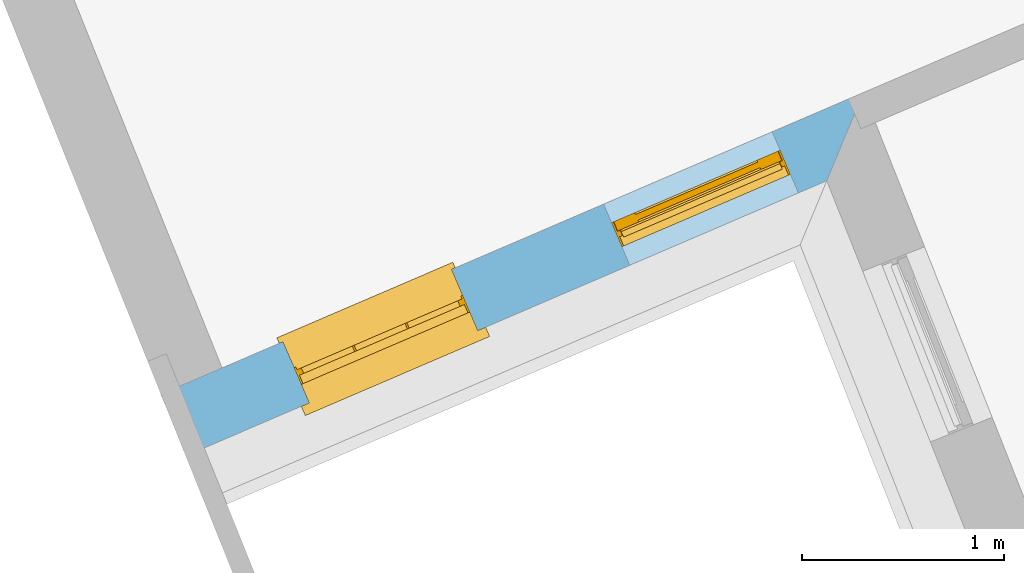
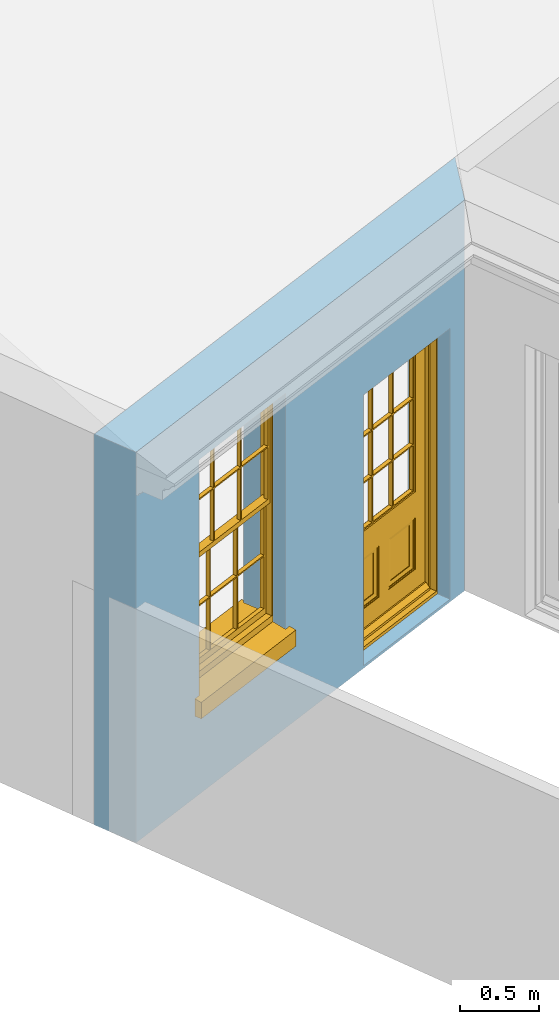
# One storey, part 10 of 19: 1 door, 1 window, 2 openings, plus 1 element that does not belong to this part.
"""IFC2X3 building model written with IfcOpenShell, lengths in metres."""

from ifc_helpers import new_model, si_unit, frame, origin, place, context, subcontext, project, spatial, polyline, outline, extrude, faceted_brep, material, layer, layer_set, layer_usage, element, fill, save


model = new_model("IFC2X3")

# Units and contexts
model_context = context("Model", 3, world=origin())
body_context = subcontext(model_context, "Body", "Model", "MODEL_VIEW")
ifc_project = project(units=[si_unit("PLANEANGLEUNIT", "RADIAN"), si_unit("MASSUNIT", "GRAM", prefix="KILO"), si_unit("FORCEUNIT", "NEWTON", prefix="KILO"), si_unit("LENGTHUNIT", "METRE")], contexts=[model_context])

# Site, building, storey
site_placement = place(None, origin())
site = spatial("IfcSite", under=ifc_project, at=site_placement, CompositionType="ELEMENT")
building_placement = place(None, origin())
building = spatial("IfcBuilding", under=site, at=building_placement, Name="Building plot-0", CompositionType="ELEMENT")
storey_placement = place(None, origin())
storey = spatial("IfcBuildingStorey", under=building, at=storey_placement, Name="Floor 0", CompositionType="ELEMENT", Elevation=0.0)

# Wall, openings, window, door
ifc_material = material(Name="Masonry")
ifc_layer = layer(ifc_material, 0.33, ventilated=False)
ifc_layer_set = layer_set([ifc_layer], Name="My Wall")
ifc_layer_usage = layer_usage(ifc_layer_set, "AXIS2", "NEGATIVE", 0.08)
wall_placement = place(storey_placement, origin())
wall = element("IfcWallStandardCase", 1, at=wall_placement, inside=storey, material=ifc_layer_usage, Name="exterior", context=body_context, shape_type="SweptSolid", body=[
    extrude(outline(polyline([(12.4783149609257, 29.6820741816785), (12.6084964326969, 29.3788370065046), (15.7818582558488, 30.741179576684), (15.9635555189143, 31.1783080951337), (12.4783149609257, 29.6820741816785)])), origin(), (0.0, 0.0, 1.0), 3.0),
])
opening_1_placement = place(storey_placement, frame((0.0, 0.0, 0.75)))
opening_1 = element("IfcOpeningElement", 2, at=opening_1_placement, cuts=wall, Name="Opening", ObjectType="Opening", context=body_context, shape_type="SweptSolid", body=[
    extrude(outline(polyline([(13.2150989386918, 29.6392549680068), (14.0512984217472, 29.9982402386486), (13.921116949976, 30.3014774138226), (13.0849174669206, 29.9424921431808), (13.2150989386918, 29.6392549680068)])), origin(), (0.0, 0.0, 1.0), 1.82),
])
opening_2_placement = place(storey_placement, frame((0.0, 0.0, 0.02)))
opening_2 = element("IfcOpeningElement", 3, at=opening_2_placement, cuts=wall, Name="Opening", ObjectType="Opening", context=body_context, shape_type="SweptSolid", body=[
    extrude(outline(polyline([(14.8050531683218, 30.3218315074543), (15.6412526513772, 30.6808167780961), (15.511071179606, 30.9840539532701), (14.6748716965506, 30.6250686826283), (14.8050531683218, 30.3218315074543)])), origin(), (0.0, 0.0, 1.0), 2.08),
])
window_placement = place(storey_placement, frame((13.1164766115924, 29.8689801007144, 0.75), z_axis=(0.0, 0.0, 1.0), x_axis=(0.836199483055472, 0.358985270641796, 0.0)))
window = element("IfcWindow", 4, at=window_placement, inside=storey, Name="bedroom outside window", OverallHeight=1.82, OverallWidth=0.91, context=body_context, shape_type="Brep", held_by="IfcProductRepresentation", body=[
    faceted_brep([(0.033125, -0.105, 0.975209), (0.01, -0.105, 0.975209), (0.033125, -0.105, 1.376042), (0.876875, -0.105, 0.975209), (0.876875, -0.105, 1.376042), (0.9, -0.105, 0.975209), (0.876875, -0.105, 1.386042), (0.876875, -0.105, 1.786875), (0.9, -0.105, 1.81), (0.033125, -0.105, 1.786875), (0.033125, -0.105, 1.386042), (0.01, -0.105, 1.81), (0.876875, -0.135, 1.376042), (0.876875, -0.135, 0.975209), (0.9, -0.135, 0.937083), (0.033125, -0.135, 1.786875), (0.01, -0.135, 1.81), (0.033125, -0.135, 1.386042), (0.01, -0.135, 0.937083), (0.033125, -0.135, 0.975209), (0.033125, -0.135, 1.376042), (0.876875, -0.135, 1.786875), (0.876875, -0.135, 1.386042), (0.9, -0.135, 1.81), (0.033125, -0.105, 0.937083), (0.01, -0.105, 0.937083), (0.033125, -0.105, 0.53625), (0.876875, -0.105, 0.937083), (0.876875, -0.105, 0.53625), (0.9, -0.105, 0.937083), (0.876875, -0.105, 0.52625), (0.876875, -0.105, 0.125417), (0.9, -0.105, 0.077167), (0.033125, -0.105, 0.125417), (0.033125, -0.105, 0.52625), (0.01, -0.105, 0.077167), (-0.0425, -0.25, 0.01), (-0.0425, -0.3, 0.001667), (0.0, -0.25, 0.01), (0.9525, -0.25, 0.01), (0.91, -0.25, 0.01), (0.9525, -0.3, 0.001667), (-0.02, 0.08, 0.077167), (0.0, 0.08, 0.077167), (-0.02, 0.11, 0.077167), (0.0, -0.06, 0.077167), (0.01, -0.06, 0.077167), (0.91, -0.06, 0.077167), (0.91, 0.08, 0.077167), (0.9, -0.06, 0.077167), (0.93, 0.08, 0.077167), (0.93, 0.11, 0.077167), (0.01, -0.075, 0.975209), (0.9, -0.075, 0.975209), (0.876875, -0.075, 0.125417), (0.876875, -0.075, 0.52625), (0.9, -0.075, 0.077167), (0.876875, -0.075, 0.53625), (0.876875, -0.075, 0.937083), (0.033125, -0.075, 0.125417), (0.01, -0.075, 0.077167), (0.033125, -0.075, 0.52625), (0.033125, -0.075, 0.937083), (0.033125, -0.075, 0.53625), (-0.02, 0.08, 0.052167), (-0.02, 0.11, 0.052167), (0.93, 0.11, 0.052167), (0.93, 0.08, 0.052167), (0.91, 0.08, 0.052167), (0.0, 0.08, 0.052167), (0.91, -0.15, 0.026667), (0.0, -0.15, 0.026667), (-0.0425, -0.3, -0.123333), (0.9525, -0.3, -0.123333), (-0.0425, -0.25, -0.123333), (0.9525, -0.25, -0.123333), (0.01, -0.06, 1.81), (0.9, -0.06, 1.81), (0.0, -0.06, 1.82), (0.91, -0.06, 1.82), (0.01, -0.15, 0.077167), (0.9, -0.15, 0.077167), (0.592292, -0.105, 0.125417), (0.592292, -0.075, 0.125417), (0.317708, -0.075, 0.125417), (0.317708, -0.105, 0.125417), (0.592292, -0.105, 0.53625), (0.317708, -0.105, 0.53625), (0.317708, -0.105, 0.52625), (0.592292, -0.105, 0.52625), (0.592292, -0.075, 0.53625), (0.317708, -0.075, 0.53625), (0.592292, -0.135, 1.386042), (0.592292, -0.105, 1.386042), (0.317708, -0.105, 1.386042), (0.317708, -0.135, 1.386042), (0.317708, -0.135, 1.376042), (0.592292, -0.135, 1.376042), (0.317708, -0.105, 1.376042), (0.592292, -0.105, 1.376042), (0.602292, -0.135, 1.376042), (0.592292, -0.135, 0.975209), (0.602292, -0.135, 0.975209), (0.602292, -0.105, 0.975209), (0.592292, -0.105, 0.975209), (0.602292, -0.105, 1.376042), (0.602292, -0.075, 0.53625), (0.602292, -0.105, 0.53625), (0.317708, -0.075, 0.52625), (0.307708, -0.075, 0.125417), (0.307708, -0.075, 0.52625), (0.602292, -0.075, 0.52625), (0.602292, -0.075, 0.125417), (0.592292, -0.075, 0.52625), (0.307708, -0.075, 0.53625), (0.317708, -0.075, 0.937083), (0.307708, -0.075, 0.937083), (0.602292, -0.075, 0.937083), (0.592292, -0.075, 0.937083), (0.307708, -0.105, 0.52625), (0.307708, -0.105, 0.125417), (0.307708, -0.105, 0.53625), (0.307708, -0.105, 0.937083), (0.592292, -0.105, 0.937083), (0.317708, -0.105, 0.937083), (0.602292, -0.105, 0.937083), (0.602292, -0.105, 0.52625), (0.602292, -0.105, 0.125417), (0.307708, -0.135, 1.386042), (0.307708, -0.135, 1.376042), (0.307708, -0.135, 0.975209), (0.317708, -0.135, 0.975209), (0.317708, -0.135, 1.786875), (0.307708, -0.135, 1.786875), (0.602292, -0.135, 1.786875), (0.592292, -0.135, 1.786875), (0.602292, -0.135, 1.386042), (0.602292, -0.105, 1.386042), (0.307708, -0.105, 1.386042), (0.307708, -0.105, 1.786875), (0.317708, -0.105, 1.786875), (0.592292, -0.105, 1.786875), (0.602292, -0.105, 1.786875), (0.307708, -0.105, 1.376042), (0.317708, -0.105, 0.975209), (0.307708, -0.105, 0.975209), (0.91, -0.15, 1.82), (0.9, -0.15, 1.81), (0.01, -0.15, 1.81), (0.0, -0.15, 1.82), (0.91, -0.25, 0.0), (0.0, -0.25, 0.0), (0.91, 0.08, 0.0), (0.0, 0.08, 0.0)], [[[0, 1, 2]], [[3, 4, 5]], [[6, 7, 8]], [[9, 10, 11]], [[12, 13, 14]], [[15, 16, 17]], [[18, 19, 20]], [[21, 22, 23]], [[24, 25, 26]], [[27, 28, 29]], [[30, 31, 32]], [[33, 34, 35]], [[14, 27, 29]], [[25, 24, 18]], [[36, 37, 38]], [[39, 40, 41]], [[42, 43, 44]], [[45, 46, 43]], [[47, 48, 49]], [[50, 51, 48]], [[1, 0, 52]], [[5, 53, 3]], [[54, 55, 56]], [[57, 58, 53]], [[59, 60, 61]], [[62, 63, 52]], [[48, 43, 46, 49]], [[51, 44, 43, 48]], [[64, 42, 44, 65]], [[65, 44, 51, 66]], [[66, 51, 50, 67]], [[65, 66, 68, 69]], [[60, 56, 49, 46]], [[70, 71, 38, 40]], [[37, 41, 40, 38]], [[37, 72, 73, 41]], [[74, 75, 73, 72]], [[8, 11, 76, 77]], [[76, 78, 79, 77]], [[32, 35, 80, 81]], [[81, 80, 71, 70]], [[82, 83, 84, 85]], [[86, 87, 88, 89]], [[86, 90, 91, 87]], [[92, 93, 94, 95]], [[92, 95, 96, 97]], [[96, 98, 99, 97]], [[100, 97, 101, 102]], [[103, 104, 99, 105]], [[97, 99, 104, 101]], [[102, 103, 105, 100]], [[28, 57, 106, 107]], [[108, 84, 109, 110]], [[111, 112, 83, 113]], [[114, 110, 61, 63]], [[90, 113, 108, 91]], [[115, 91, 114, 116]], [[117, 106, 90, 118]], [[111, 106, 57, 55]], [[119, 110, 109, 120]], [[34, 61, 110, 119]], [[89, 113, 83, 82]], [[88, 108, 113, 89]], [[85, 84, 108, 88]], [[121, 114, 63, 26]], [[122, 116, 114, 121]], [[123, 118, 90, 86]], [[87, 91, 115, 124]], [[107, 106, 117, 125]], [[126, 111, 55, 30]], [[127, 112, 111, 126]], [[126, 30, 28, 107]], [[88, 119, 120, 85]], [[126, 89, 82, 127]], [[125, 123, 86, 107]], [[121, 26, 34, 119]], [[124, 122, 121, 87]], [[128, 17, 20, 129]], [[96, 129, 130, 131]], [[132, 133, 128, 95]], [[134, 135, 92, 136]], [[100, 12, 22, 136]], [[137, 6, 4, 105]], [[94, 138, 139, 140]], [[137, 93, 141, 142]], [[99, 98, 94, 93]], [[143, 2, 10, 138]], [[144, 145, 143, 98]], [[129, 143, 145, 130]], [[20, 2, 143, 129]], [[131, 144, 98, 96]], [[128, 138, 10, 17]], [[133, 139, 138, 128]], [[135, 141, 93, 92]], [[95, 94, 140, 132]], [[22, 6, 137, 136]], [[136, 137, 142, 134]], [[100, 105, 4, 12]], [[107, 86, 89, 126]], [[106, 111, 113, 90]], [[91, 108, 110, 114]], [[87, 121, 119, 88]], [[97, 100, 136, 92]], [[129, 96, 95, 128]], [[98, 143, 138, 94]], [[105, 99, 93, 137]], [[131, 101, 104, 144]], [[124, 115, 118, 123]], [[132, 140, 141, 135]], [[120, 109, 59, 33]], [[15, 9, 139, 133]], [[134, 142, 7, 21]], [[31, 54, 112, 127]], [[36, 74, 72, 37]], [[39, 41, 73, 75]], [[18, 14, 101, 131]], [[23, 16, 132, 135]], [[83, 56, 60, 84]], [[52, 53, 118, 115]], [[53, 52, 144, 104]], [[11, 8, 141, 140]], [[14, 18, 124, 123]], [[2, 1, 11, 10]], [[8, 5, 4, 6]], [[57, 53, 56, 55]], [[60, 52, 63, 61]], [[26, 25, 35, 34]], [[32, 29, 28, 30]], [[14, 23, 22, 12]], [[18, 20, 17, 16]], [[19, 0, 2, 20]], [[17, 10, 9, 15]], [[12, 4, 3, 13]], [[21, 7, 6, 22]], [[27, 58, 57, 28]], [[30, 55, 54, 31]], [[33, 59, 61, 34]], [[26, 63, 62, 24]], [[5, 8, 77, 53]], [[76, 11, 1, 52]], [[46, 45, 78, 76]], [[49, 77, 79, 47]], [[70, 146, 147, 81]], [[71, 80, 148, 149]], [[19, 130, 145, 0]], [[102, 13, 3, 103]], [[116, 122, 24, 62]], [[29, 32, 81, 14]], [[80, 35, 25, 18]], [[60, 46, 76, 52]], [[77, 49, 56, 53]], [[23, 14, 81, 147]], [[16, 148, 80, 18]], [[35, 85, 120]], [[120, 33, 35]], [[127, 82, 32]], [[32, 31, 127]], [[32, 82, 85, 35]], [[102, 101, 14]], [[14, 13, 102]], [[18, 131, 130]], [[130, 19, 18]], [[134, 21, 23]], [[23, 135, 134]], [[16, 15, 133]], [[133, 132, 16]], [[11, 140, 139]], [[139, 9, 11]], [[142, 141, 8]], [[8, 7, 142]], [[23, 147, 148, 16]], [[146, 149, 148, 147]], [[52, 115, 116]], [[116, 62, 52]], [[118, 53, 117]], [[58, 117, 53]], [[27, 125, 117, 58]], [[56, 83, 112]], [[112, 54, 56]], [[109, 84, 60]], [[60, 59, 109]], [[125, 27, 14]], [[14, 123, 125]], [[122, 124, 18]], [[18, 24, 122]], [[145, 144, 52]], [[52, 0, 145]], [[103, 3, 53]], [[53, 104, 103]], [[79, 78, 149, 146]], [[78, 45, 71, 149]], [[146, 70, 47, 79]], [[150, 75, 74, 151]], [[68, 66, 67]], [[48, 68, 67, 50]], [[69, 64, 65]], [[42, 64, 69, 43]], [[69, 68, 152, 153]], [[70, 68, 48, 47]], [[150, 152, 68, 70]], [[43, 69, 71, 45]], [[69, 153, 151, 71]], [[152, 150, 151, 153]], [[38, 151, 74, 36]], [[71, 151, 38]], [[39, 75, 150, 40]], [[40, 150, 70]]]),
])
fill(opening_1, window)
door_placement = place(storey_placement, frame((14.7064308412224, 30.5515566401619, 0.02), z_axis=(0.0, 0.0, 1.0), x_axis=(0.836199483055472, 0.358985270641796, 0.0)))
door = element("IfcDoor", 5, at=door_placement, inside=storey, Name="bedroom outside door", OverallHeight=2.08, OverallWidth=0.91, context=body_context, shape_type="Brep", held_by="IfcProductRepresentation", body=[
    faceted_brep([(0.545, -0.055, 0.265), (0.745, -0.055, 0.265), (0.745, -0.05, 0.265), (0.545, -0.05, 0.265), (0.745, -0.05, 0.58), (0.545, -0.05, 0.58), (0.545, -0.055, 0.58), (0.515, -0.06, 0.235), (0.775, -0.06, 0.235), (0.745, -0.055, 0.58), (0.515, -0.06, 0.61), (0.515, -0.065, 0.235), (0.775, -0.065, 0.235), (0.775, -0.06, 0.61), (0.515, -0.065, 0.61), (0.785, -0.065, 0.225), (0.505, -0.065, 0.225), (0.775, -0.065, 0.61), (0.505, -0.065, 0.62), (0.785, -0.065, 0.62), (0.505, -0.07, 0.225), (0.785, -0.07, 0.225), (0.505, -0.07, 0.62), (0.785, -0.07, 0.62), (0.883, -0.07, 0.075), (0.898, -0.07, 0.075), (0.405, -0.07, 0.62), (0.405, -0.07, 0.225), (0.027, -0.07, 0.075), (0.785, -0.07, 0.82), (0.125, -0.07, 0.82), (0.405, -0.065, 0.62), (0.405, -0.065, 0.225), (0.898, -0.07, 2.068), (0.027, -0.08, 0.075), (0.883, -0.08, 0.075), (0.125, -0.07, 0.225), (0.012, -0.07, 0.075), (0.785, -0.06, 0.82), (0.125, -0.06, 0.82), (0.125, -0.07, 0.62), (0.125, -0.065, 0.62), (0.395, -0.065, 0.61), (0.395, -0.065, 0.235), (0.125, -0.065, 0.225), (0.785, -0.07, 1.895), (0.027, -0.11, 0.045), (0.883, -0.11, 0.045), (0.558333, -0.06, 0.83), (0.351667, -0.06, 0.83), (0.125, -0.07, 1.895), (0.125, -0.06, 1.895), (0.785, -0.06, 1.895), (0.012, -0.07, 2.068), (0.135, -0.065, 0.61), (0.395, -0.06, 0.61), (0.395, -0.06, 0.235), (0.135, -0.065, 0.235), (0.027, -0.11, 0.027), (0.883, -0.11, 0.027), (0.568333, -0.06, 0.83), (0.558333, -0.03, 0.83), (0.351667, -0.03, 0.83), (0.341667, -0.06, 0.83), (0.135, -0.06, 1.185), (0.135, -0.06, 1.53), (0.775, -0.06, 1.53), (0.775, -0.06, 1.185), (0.135, -0.06, 0.61), (0.365, -0.055, 0.58), (0.365, -0.055, 0.265), (0.135, -0.06, 0.235), (0.568333, -0.06, 1.175), (0.558333, -0.06, 1.175), (0.775, -0.06, 0.83), (0.558333, -0.03, 1.175), (0.785, -0.03, 0.82), (0.125, -0.03, 0.82), (0.351667, -0.03, 1.175), (0.351667, -0.06, 1.175), (0.341667, -0.06, 1.175), (0.135, -0.06, 0.83), (0.135, -0.06, 1.175), (0.135, -0.03, 1.185), (0.135, -0.03, 1.53), (0.135, -0.06, 1.54), (0.351667, -0.06, 1.885), (0.558333, -0.06, 1.885), (0.775, -0.03, 1.53), (0.775, -0.03, 1.185), (0.775, -0.06, 1.175), (0.775, -0.06, 1.54), (0.165, -0.055, 0.58), (0.365, -0.05, 0.58), (0.365, -0.05, 0.265), (0.165, -0.055, 0.265), (0.568333, -0.03, 0.83), (0.568333, -0.03, 1.175), (0.568333, -0.06, 1.185), (0.558333, -0.06, 1.185), (0.775, -0.03, 0.83), (0.785, -0.02, 0.82), (0.125, -0.02, 0.82), (0.341667, -0.03, 0.83), (0.341667, -0.03, 1.175), (0.351667, -0.06, 1.185), (0.341667, -0.06, 1.185), (0.135, -0.03, 0.83), (0.341667, -0.03, 1.185), (0.125, -0.03, 1.895), (0.341667, -0.03, 1.53), (0.341667, -0.06, 1.53), (0.135, -0.06, 1.885), (0.341667, -0.06, 1.54), (0.341667, -0.06, 1.885), (0.558333, -0.03, 1.885), (0.351667, -0.03, 1.885), (0.568333, -0.06, 1.885), (0.785, -0.03, 1.895), (0.568333, -0.03, 1.185), (0.568333, -0.06, 1.53), (0.568333, -0.03, 1.53), (0.568333, -0.06, 1.54), (0.775, -0.06, 1.885), (0.165, -0.05, 0.58), (0.165, -0.05, 0.265), (0.775, -0.03, 1.175), (0.558333, -0.06, 1.53), (0.351667, -0.03, 1.185), (0.558333, -0.03, 1.185), (0.505, -0.02, 0.62), (0.405, -0.02, 0.62), (0.125, -0.02, 1.895), (0.785, -0.02, 1.895), (0.351667, -0.06, 1.53), (0.135, -0.03, 1.175), (0.135, -0.03, 1.54), (0.341667, -0.03, 1.54), (0.135, -0.03, 1.885), (0.351667, -0.06, 1.54), (0.558333, -0.03, 1.54), (0.558333, -0.06, 1.54), (0.351667, -0.03, 1.54), (0.775, -0.03, 1.54), (0.568333, -0.03, 1.54), (0.775, -0.03, 1.885), (0.558333, -0.03, 1.53), (0.405, -0.02, 0.225), (0.505, -0.02, 0.225), (0.125, -0.02, 0.62), (0.785, -0.02, 0.62), (0.012, -0.02, 2.068), (0.898, -0.02, 2.068), (0.351667, -0.03, 1.53), (0.341667, -0.03, 1.885), (0.568333, -0.03, 1.885), (0.405, -0.025, 0.225), (0.405, -0.025, 0.62), (0.505, -0.025, 0.62), (0.505, -0.025, 0.225), (0.898, -0.02, 0.027), (0.012, -0.02, 0.027), (0.125, -0.025, 0.62), (0.785, -0.025, 0.62), (0.395, -0.025, 0.235), (0.395, -0.025, 0.61), (0.125, -0.02, 0.225), (0.125, -0.025, 0.225), (0.515, -0.025, 0.61), (0.515, -0.025, 0.235), (0.785, -0.02, 0.225), (0.785, -0.025, 0.225), (0.135, -0.025, 0.61), (0.775, -0.025, 0.61), (0.135, -0.025, 0.235), (0.395, -0.03, 0.235), (0.395, -0.03, 0.61), (0.515, -0.03, 0.61), (0.515, -0.03, 0.235), (0.775, -0.025, 0.235), (0.135, -0.03, 0.61), (0.775, -0.03, 0.61), (0.135, -0.03, 0.235), (0.365, -0.035, 0.265), (0.365, -0.035, 0.58), (0.545, -0.035, 0.58), (0.545, -0.035, 0.265), (0.775, -0.03, 0.235), (0.165, -0.035, 0.58), (0.745, -0.035, 0.58), (0.165, -0.035, 0.265), (0.365, -0.04, 0.58), (0.365, -0.04, 0.265), (0.545, -0.04, 0.58), (0.545, -0.04, 0.265), (0.745, -0.035, 0.265), (0.165, -0.04, 0.58), (0.745, -0.04, 0.58), (0.165, -0.04, 0.265), (0.745, -0.04, 0.265), (0.885, -0.072, 0.025), (0.025, -0.072, 0.025), (0.025, -0.1, 0.025), (0.885, -0.1, 0.025), (0.9, -0.02, 0.025), (0.01, -0.02, 0.025), (0.9, -0.072, 0.025), (0.91, -0.02, 0.0), (0.0, -0.02, 0.0), (0.01, -0.072, 0.025), (0.9, -0.072, 2.07), (0.9, -0.02, 2.07), (0.885, -0.072, 2.055), (0.91, -0.02, 2.08), (0.01, -0.02, 2.07), (0.0, -0.02, 2.08), (0.01, -0.072, 2.07), (0.025, -0.072, 2.055), (0.0, -0.15, 2.08), (0.91, -0.15, 2.08), (0.01, -0.15, 2.07), (0.9, -0.15, 2.07), (0.01, -0.1, 2.07), (0.9, -0.1, 2.07), (0.0, -0.15, 0.0), (0.91, -0.15, 0.0), (0.01, -0.15, 0.025), (0.9, -0.15, 0.025), (0.01, -0.1, 0.025), (0.025, -0.1, 2.055), (0.9, -0.1, 0.025), (0.885, -0.1, 2.055), (0.898, -0.07, 0.027), (0.012, -0.07, 0.027), (0.883, -0.07, 0.027), (0.027, -0.07, 0.027)], [[[0, 1, 2, 3]], [[2, 4, 5, 3]], [[0, 3, 5, 6]], [[1, 0, 7, 8]], [[9, 4, 2, 1]], [[9, 6, 5, 4]], [[0, 6, 10, 7]], [[8, 7, 11, 12]], [[8, 13, 9, 1]], [[13, 10, 6, 9]], [[7, 10, 14, 11]], [[15, 12, 11, 16]], [[12, 17, 13, 8]], [[17, 14, 10, 13]], [[18, 16, 11, 14]], [[15, 19, 17, 12]], [[15, 16, 20, 21]], [[14, 17, 19, 18]], [[16, 18, 22, 20]], [[21, 23, 19, 15]], [[24, 25, 21, 20]], [[23, 22, 18, 19]], [[20, 22, 26, 27]], [[23, 21, 25]], [[28, 24, 20, 27]], [[22, 23, 29]], [[29, 30, 26, 22]], [[27, 26, 31, 32]], [[23, 25, 33, 29]], [[34, 35, 24, 28]], [[28, 27, 36, 37]], [[38, 39, 30, 29]], [[26, 30, 40]], [[26, 40, 41, 31]], [[42, 43, 32, 31]], [[32, 44, 36, 27]], [[33, 45, 29]], [[46, 47, 35, 34]], [[36, 40, 37]], [[39, 38, 48, 49]], [[50, 30, 39, 51]], [[29, 45, 52, 38]], [[53, 37, 40, 30]], [[44, 41, 40, 36]], [[31, 41, 54, 42]], [[43, 42, 55, 56]], [[57, 44, 32, 43]], [[50, 45, 33, 53]], [[47, 46, 58, 59]], [[60, 48, 38]], [[49, 48, 61, 62]], [[49, 63, 39]], [[50, 53, 30]], [[51, 39, 64, 65]], [[45, 50, 51, 52]], [[66, 67, 38, 52]], [[57, 54, 41, 44]], [[42, 54, 68, 55]], [[56, 55, 69, 70]], [[56, 71, 57, 43]], [[60, 72, 73, 48]], [[60, 38, 74]], [[48, 73, 75, 61]], [[76, 77, 62, 61]], [[62, 78, 79, 49]], [[49, 79, 80, 63]], [[63, 81, 39]], [[82, 64, 39]], [[65, 64, 83, 84]], [[85, 51, 65]], [[52, 51, 86, 87]], [[88, 89, 67, 66]], [[90, 38, 67]], [[91, 66, 52]], [[71, 68, 54, 57]], [[55, 68, 92, 69]], [[69, 93, 94, 70]], [[70, 95, 71, 56]], [[96, 97, 72, 60]], [[73, 72, 98, 99]], [[74, 38, 90]], [[100, 96, 60, 74]], [[75, 73, 79, 78]], [[61, 75, 97, 96]], [[101, 102, 77, 76]], [[77, 103, 62]], [[96, 76, 61]], [[103, 104, 78, 62]], [[80, 79, 105, 106]], [[63, 80, 104, 103]], [[81, 63, 103, 107]], [[81, 82, 39]], [[106, 64, 82, 80]], [[106, 108, 83, 64]], [[84, 83, 77, 109]], [[110, 111, 65, 84]], [[112, 51, 85]], [[113, 85, 65, 111]], [[114, 86, 51]], [[115, 87, 86, 116]], [[117, 52, 87]], [[118, 76, 89, 88]], [[119, 98, 67, 89]], [[120, 121, 88, 66]], [[67, 98, 72, 90]], [[91, 122, 120, 66]], [[91, 52, 123]], [[95, 92, 68, 71]], [[69, 92, 124, 93]], [[94, 93, 124, 125]], [[94, 125, 95, 70]], [[72, 97, 126, 90]], [[127, 99, 98, 120]], [[99, 105, 79, 73]], [[74, 90, 126, 100]], [[96, 100, 76]], [[128, 129, 75, 78]], [[97, 75, 129, 119]], [[130, 131, 102, 101]], [[109, 77, 102, 132]], [[133, 101, 76, 118]], [[77, 107, 103]], [[78, 104, 108, 128]], [[111, 106, 105, 134]], [[104, 80, 82, 135]], [[107, 135, 82, 81]], [[110, 108, 106, 111]], [[104, 135, 83, 108]], [[83, 135, 77]], [[136, 84, 109]], [[110, 84, 136, 137]], [[114, 51, 112]], [[85, 136, 138, 112]], [[113, 137, 136, 85]], [[111, 134, 139, 113]], [[86, 114, 113, 139]], [[140, 141, 87, 115]], [[139, 142, 116, 86]], [[109, 118, 115, 116]], [[117, 123, 52]], [[117, 87, 141, 122]], [[126, 89, 76]], [[143, 118, 88]], [[120, 98, 119, 121]], [[119, 89, 126, 97]], [[144, 143, 88, 121]], [[144, 122, 91, 143]], [[127, 120, 122, 141]], [[143, 91, 123, 145]], [[124, 92, 95, 125]], [[146, 129, 99, 127]], [[99, 129, 128, 105]], [[100, 126, 76]], [[121, 119, 129, 146]], [[147, 131, 130, 148]], [[131, 149, 102]], [[130, 101, 150]], [[102, 151, 132]], [[118, 109, 132, 133]], [[101, 133, 152]], [[107, 77, 135]], [[153, 128, 108, 110]], [[134, 105, 128, 153]], [[109, 138, 136]], [[153, 110, 137, 142]], [[154, 114, 112, 138]], [[137, 113, 114, 154]], [[141, 139, 134, 127]], [[141, 140, 142, 139]], [[144, 140, 115, 155]], [[142, 137, 154, 116]], [[155, 115, 118]], [[116, 154, 109]], [[117, 155, 145, 123]], [[122, 144, 155, 117]], [[143, 145, 118]], [[121, 146, 140, 144]], [[146, 127, 134, 153]], [[156, 157, 131, 147]], [[148, 130, 158, 159]], [[148, 160, 161, 147]], [[157, 162, 149, 131]], [[161, 151, 102, 149]], [[101, 152, 160, 150]], [[163, 158, 130, 150]], [[151, 152, 133, 132]], [[154, 138, 109]], [[142, 140, 146, 153]], [[145, 155, 118]], [[157, 156, 164, 165]], [[147, 166, 167, 156]], [[168, 169, 159, 158]], [[170, 148, 159, 171]], [[148, 170, 160]], [[166, 147, 161]], [[172, 162, 157, 165]], [[166, 149, 162, 167]], [[166, 161, 149]], [[150, 160, 170]], [[163, 173, 168, 158]], [[171, 163, 150, 170]], [[174, 164, 156, 167]], [[175, 176, 165, 164]], [[169, 168, 177, 178]], [[171, 159, 169, 179]], [[167, 162, 172, 174]], [[176, 180, 172, 165]], [[179, 173, 163, 171]], [[181, 177, 168, 173]], [[164, 174, 182, 175]], [[183, 184, 176, 175]], [[178, 177, 185, 186]], [[179, 169, 178, 187]], [[174, 172, 180, 182]], [[184, 188, 180, 176]], [[187, 181, 173, 179]], [[189, 185, 177, 181]], [[175, 182, 190, 183]], [[191, 184, 183, 192]], [[185, 193, 194, 186]], [[187, 178, 186, 195]], [[182, 180, 188, 190]], [[191, 196, 188, 184]], [[195, 189, 181, 187]], [[197, 193, 185, 189]], [[183, 190, 198, 192]], [[198, 196, 191, 192]], [[194, 193, 197, 199]], [[195, 186, 194, 199]], [[188, 196, 198, 190]], [[197, 189, 195, 199]], [[200, 201, 202, 203]], [[201, 200, 204, 205]], [[206, 204, 200]], [[204, 207, 208, 205]], [[209, 201, 205]], [[210, 211, 204, 206]], [[206, 200, 212, 210]], [[211, 213, 207, 204]], [[214, 205, 208, 215]], [[216, 217, 201, 209]], [[205, 214, 216, 209]], [[216, 214, 211, 210]], [[210, 212, 217, 216]], [[214, 215, 213, 211]], [[218, 219, 213, 215]], [[219, 218, 220, 221]], [[221, 220, 222, 223]], [[215, 208, 224, 218]], [[225, 224, 208, 207]], [[224, 226, 220, 218]], [[224, 225, 227, 226]], [[219, 225, 207, 213]], [[228, 222, 220, 226]], [[219, 221, 227, 225]], [[226, 227, 203, 202]], [[202, 229, 222, 228]], [[228, 226, 202]], [[227, 221, 223, 230]], [[230, 203, 227]], [[217, 229, 202, 201]], [[231, 223, 222, 229]], [[230, 223, 231, 203]], [[231, 229, 217, 212]], [[212, 200, 203, 231]], [[33, 152, 151, 53]], [[25, 160, 152, 33]], [[161, 37, 53, 151]], [[232, 160, 25]], [[161, 233, 37]], [[160, 232, 234]], [[24, 234, 232, 25]], [[233, 161, 235]], [[37, 233, 235, 28]], [[161, 160, 234, 235]], [[35, 47, 234, 24]], [[28, 235, 46, 34]], [[58, 235, 234, 59]], [[59, 234, 47]], [[58, 46, 235]]]),
])
fill(opening_2, door)

save(model, "model.ifc")
